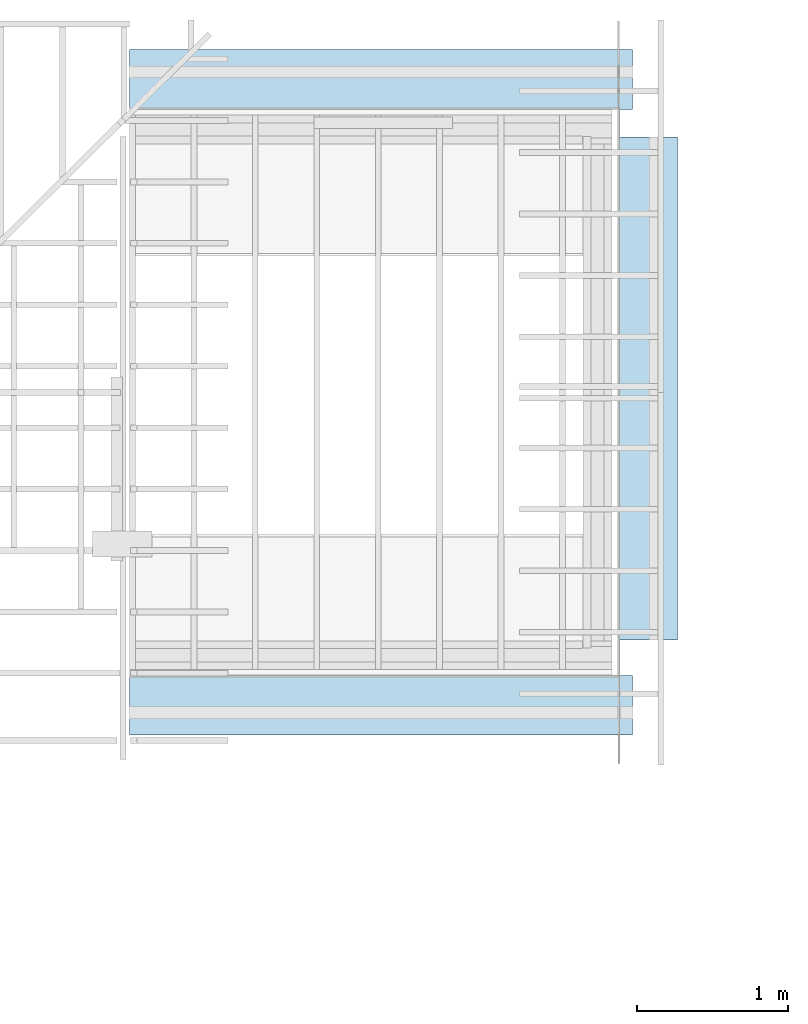
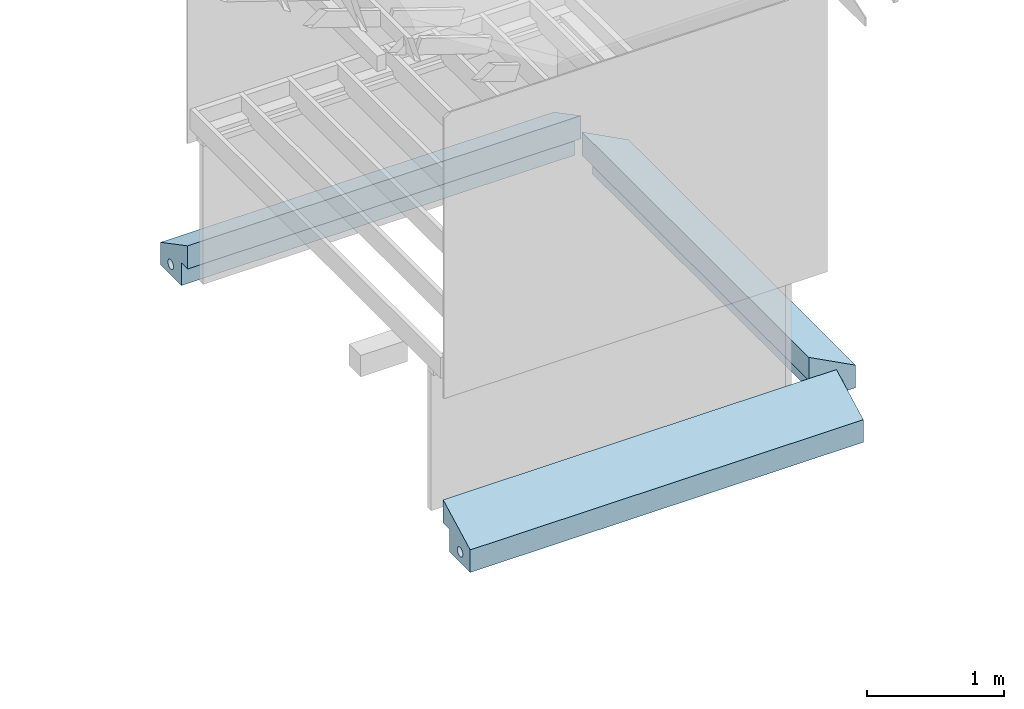
# Not in any storey, part 5 of 8: 3 footings.
"""IFC4 model written with IfcOpenShell, lengths in feet."""

from ifc_helpers import new_model, entity, si_unit, converted_unit, frame, origin_with_axes, origin_2d_with_axis, place, context, subcontext, project, polygons, material, element, save


model = new_model("IFC4")

# Units and contexts
model_context = context("Model", 3, precision=1e-05, world=origin_with_axes())
plan_context = context("Plan", 2, precision=1e-05, world=origin_2d_with_axis())
context_of_model_1 = context(None, 3, precision=1e-05, world=origin_with_axes())
context_of_model_2 = context(None, 3, precision=1e-05, world=origin_with_axes())
body_context = subcontext(model_context, "Body", "Model", "MODEL_VIEW")
ifc_project = project(units=[converted_unit("PLANEANGLEUNIT", "degree", entity("IfcReal", 0.0174532925199433), si_unit("PLANEANGLEUNIT", "RADIAN"), dimensions=[0, 0, 0, 0, 0, 0, 0]), converted_unit("AREAUNIT", "square foot", entity("IfcReal", 0.09290304), si_unit("AREAUNIT", "SQUARE_METRE"), dimensions=[2, 0, 0, 0, 0, 0, 0]), converted_unit("LENGTHUNIT", "foot", entity("IfcReal", 0.3048), si_unit("LENGTHUNIT", "METRE"), dimensions=[1, 0, 0, 0, 0, 0, 0]), converted_unit("VOLUMEUNIT", "cubic foot", entity("IfcReal", 0.0283168467116885), si_unit("VOLUMEUNIT", "CUBIC_METRE"), dimensions=[3, 0, 0, 0, 0, 0, 0])], contexts=[model_context, plan_context, context_of_model_1, context_of_model_2])

# Footings
ifc_material = material(Name="FILTER FABRIC OVER COARSE GRAVEL (NO)", Category="sand")
footing_1_placement = place(None, frame((-8.20750795950101, 9.42573459755404, -5.49999865021293), z_axis=(0.999999999999997, 0.0, 7.54979012640431e-08), x_axis=(7.54979012640431e-08, 0.0, -0.999999999999997)))
element("IfcFooting", 1, at=footing_1_placement, material=ifc_material, Name="Plane", ObjectType="Backfill", PredefinedType="USERDEFINED", context=body_context, shape_type="Tessellation", body=[
    polygons([(-0.336403906345367, 0.64263528585434, -2.71372056007385), (-0.361569315195084, 0.635001599788666, -2.71372056007385), (-0.384761482477188, 0.622605204582214, -2.71372056007385), (-0.405089259147644, 0.605922102928162, -2.71372056007385), (-0.421772688627243, 0.585593938827515, -2.71372056007385), (-0.434169232845306, 0.562402188777924, -2.71372056007385), (-1.34549736976624, -0.299155086278915, 8.19978809356689), (6.19066838680737e-07, 0.0, 8.19978809356689), (6.19066838680737e-07, 0.999586641788483, 8.19978809356689), (-0.666665971279144, 0.0, 8.19978809356689), (-0.662689328193665, 0.999585866928101, 8.19978809356689), (-0.666665971279144, -0.299155086278915, 8.19978809356689), (-0.310232996940613, 0.645212650299072, 8.19978809356689), (-0.284061670303345, 0.64263528585434, 8.19978809356689), (-0.258896738290787, 0.635001659393311, 8.19978809356689), (-0.235704496502876, 0.62260502576828, 8.19978809356689), (-0.215376317501068, 0.605922043323517, 8.19978809356689), (-0.198693662881851, 0.58559387922287, 8.19978809356689), (-0.18629752099514, 0.562402069568634, 8.19978809356689), (-0.17866313457489, 0.537236750125885, 8.19978809356689), (-0.176086127758026, 0.511066198348999, 8.19978809356689), (-0.17866313457489, 0.484895616769791, 8.19978809356689), (-0.18629752099514, 0.459731042385101, 8.19978809356689), (-0.198693662881851, 0.436537683010101, 8.19978809356689), (-0.215376317501068, 0.416211098432541, 8.19978809356689), (-0.235704496502876, 0.399528026580811, 8.19978809356689), (-0.258896708488464, 0.38713151216507, 8.19978809356689), (-0.284061670303345, 0.379497855901718, 8.19978809356689), (-0.310232996940613, 0.376918911933899, 8.19978809356689), (-0.336403071880341, 0.379497855901718, 8.19978809356689), (-0.361568480730057, 0.387131482362747, 8.19978809356689), (-0.384760707616806, 0.399528056383133, 8.19978809356689), (-0.405088424682617, 0.416211098432541, 8.19978809356689), (-0.421771883964539, 0.436537742614746, 8.19978809356689), (-0.43416839838028, 0.459731131792068, 8.19978809356689), (-0.441801637411118, 0.484895616769791, 8.19978809356689), (-0.444379419088364, 0.511066198348999, 8.19978809356689), (-0.441801637411118, 0.537236750125885, 8.19978809356689), (-0.43416839838028, 0.562402188777924, 8.19978809356689), (-0.421771854162216, 0.585593938827515, 8.19978809356689), (-0.405088424682617, 0.605922102928162, 8.19978809356689), (-0.384760648012161, 0.622605204582214, 8.19978809356689), (-0.361568480730057, 0.635001599788666, 8.19978809356689), (-0.336403071880341, 0.64263528585434, 8.19978809356689), (-0.441802471876144, 0.537236750125885, -2.71372056007385), (-0.444380253553391, 0.511066198348999, -2.71372056007385), (-0.441802471876144, 0.484895616769791, -2.71372056007385), (-0.434169232845306, 0.459731131792068, -2.71372056007385), (-0.421772718429565, 0.436537742614746, -2.71372056007385), (-0.405089229345322, 0.416211098432541, -2.71372056007385), (-0.38476151227951, 0.399528056383133, -2.71372056007385), (-0.361569315195084, 0.387131482362747, -2.71372056007385), (-0.336403906345367, 0.379497855901718, -2.71372056007385), (-0.31023383140564, 0.376918911933899, -2.71372056007385), (-0.284062504768372, 0.379497855901718, -2.71372056007385), (-0.258897542953491, 0.38713151216507, -2.71372056007385), (-0.235705330967903, 0.399528026580811, -2.71372056007385), (-0.215377151966095, 0.416211098432541, -2.71372056007385), (-0.198694482445717, 0.436537683010101, -2.71372056007385), (-0.186298340559006, 0.459731042385101, -2.71372056007385), (-0.178663939237595, 0.484895616769791, -2.71372056007385), (-0.176086947321892, 0.511066198348999, -2.71372056007385), (-0.178663939237595, 0.537236750125885, -2.71372056007385), (-0.186298340559006, 0.562402069568634, -2.71372056007385), (-0.198694482445717, 0.58559387922287, -2.71372056007385), (-0.215377151966095, 0.605922043323517, -2.71372056007385), (-0.235705330967903, 0.62260502576828, -2.71372056007385), (-0.258897572755814, 0.635001659393311, -2.71372056007385), (-0.284062504768372, 0.64263528585434, -2.71372056007385), (-0.31023383140564, 0.645212650299072, -2.71372056007385), (-0.666666805744171, -0.299155086278915, -2.71372056007385), (-0.662690162658691, 0.999585866928101, -2.71372056007385), (-0.666666805744171, 0.0, -2.71372056007385), (-2.04880194587531e-07, 0.999586641788483, -2.71372056007385), (-2.04880194587531e-07, 0.0, -2.71372056007385), (-1.34549808502197, -0.299155086278915, -2.71372056007385)], [[[47, 48, 49, 50, 51, 52, 53, 54, 55, 56, 57, 58, 59, 60, 61, 62, 74, 75, 73, 71, 76, 72, 46]], [[11, 37, 38, 39, 40, 41, 42, 43, 44, 13, 14, 15, 16, 17, 18, 19, 20, 21, 9]], [[37, 36, 47, 46]], [[24, 23, 60, 59]], [[36, 35, 48, 47]], [[38, 37, 46, 45]], [[23, 22, 61, 60]], [[72, 74, 62, 63, 64, 65, 66, 67, 68, 69, 70, 1, 2, 3, 4, 5, 6, 45, 46]], [[36, 37, 11, 7, 12, 10, 8, 9, 21, 22, 23, 24, 25, 26, 27, 28, 29, 30, 31, 32, 33, 34, 35]], [[25, 24, 59, 58]], [[39, 38, 45, 6]], [[26, 25, 58, 57]], [[40, 39, 6, 5]], [[27, 26, 57, 56]], [[14, 13, 70, 69]], [[41, 40, 5, 4]], [[28, 27, 56, 55]], [[15, 14, 69, 68]], [[42, 41, 4, 3]], [[7, 11, 72, 76]], [[29, 28, 55, 54]], [[16, 15, 68, 67]], [[43, 42, 3, 2]], [[9, 8, 75, 74]], [[30, 29, 54, 53]], [[17, 16, 67, 66]], [[44, 43, 2, 1]], [[11, 9, 74, 72]], [[31, 30, 53, 52]], [[18, 17, 66, 65]], [[13, 44, 1, 70]], [[10, 12, 71, 73]], [[32, 31, 52, 51]], [[19, 18, 65, 64]], [[12, 7, 76, 71]], [[33, 32, 51, 50]], [[20, 19, 64, 63]], [[8, 10, 73, 75]], [[34, 33, 50, 49]], [[21, 20, 63, 62]], [[35, 34, 49, 48]], [[22, 21, 62, 61]]], closed=True),
])
footing_2_placement = place(None, frame((-8.20750795950101, -3.45877931499731, -5.49999865021293), z_axis=(0.999999999999997, 0.0, 7.54979012640431e-08), x_axis=(7.54979012640431e-08, 0.0, -0.999999999999997)))
element("IfcFooting", 2, at=footing_2_placement, material=ifc_material, Name="Plane", ObjectType="Backfill", PredefinedType="USERDEFINED", context=body_context, shape_type="Tessellation", body=[
    polygons([(-0.336403906345367, -0.64263528585434, -2.71372056007385), (-0.361569315195084, -0.635001599788666, -2.71372056007385), (-0.384761482477188, -0.622605204582214, -2.71372056007385), (-0.405089259147644, -0.605922102928162, -2.71372056007385), (-0.421772688627243, -0.585593938827515, -2.71372056007385), (-0.434169232845306, -0.562402188777924, -2.71372056007385), (-1.34549736976624, 0.299155086278915, 8.19978809356689), (6.19066838680737e-07, 0.0, 8.19978809356689), (6.19066838680737e-07, -0.999586641788483, 8.19978809356689), (-0.666665971279144, 0.0, 8.19978809356689), (-0.662689328193665, -0.999585866928101, 8.19978809356689), (-0.666665971279144, 0.299155086278915, 8.19978809356689), (-0.310232996940613, -0.645212650299072, 8.19978809356689), (-0.284061670303345, -0.64263528585434, 8.19978809356689), (-0.258896738290787, -0.635001659393311, 8.19978809356689), (-0.235704496502876, -0.62260502576828, 8.19978809356689), (-0.215376317501068, -0.605922043323517, 8.19978809356689), (-0.198693662881851, -0.58559387922287, 8.19978809356689), (-0.18629752099514, -0.562402069568634, 8.19978809356689), (-0.17866313457489, -0.537236750125885, 8.19978809356689), (-0.176086127758026, -0.511066198348999, 8.19978809356689), (-0.17866313457489, -0.484895616769791, 8.19978809356689), (-0.18629752099514, -0.459731042385101, 8.19978809356689), (-0.198693662881851, -0.436537683010101, 8.19978809356689), (-0.215376317501068, -0.416211098432541, 8.19978809356689), (-0.235704496502876, -0.399528026580811, 8.19978809356689), (-0.258896708488464, -0.38713151216507, 8.19978809356689), (-0.284061670303345, -0.379497855901718, 8.19978809356689), (-0.310232996940613, -0.376918911933899, 8.19978809356689), (-0.336403071880341, -0.379497855901718, 8.19978809356689), (-0.361568480730057, -0.387131482362747, 8.19978809356689), (-0.384760707616806, -0.399528056383133, 8.19978809356689), (-0.405088424682617, -0.416211098432541, 8.19978809356689), (-0.421771883964539, -0.436537742614746, 8.19978809356689), (-0.43416839838028, -0.459731131792068, 8.19978809356689), (-0.441801637411118, -0.484895616769791, 8.19978809356689), (-0.444379419088364, -0.511066198348999, 8.19978809356689), (-0.441801637411118, -0.537236750125885, 8.19978809356689), (-0.43416839838028, -0.562402188777924, 8.19978809356689), (-0.421771854162216, -0.585593938827515, 8.19978809356689), (-0.405088424682617, -0.605922102928162, 8.19978809356689), (-0.384760648012161, -0.622605204582214, 8.19978809356689), (-0.361568480730057, -0.635001599788666, 8.19978809356689), (-0.336403071880341, -0.64263528585434, 8.19978809356689), (-0.441802471876144, -0.537236750125885, -2.71372056007385), (-0.444380253553391, -0.511066198348999, -2.71372056007385), (-0.441802471876144, -0.484895616769791, -2.71372056007385), (-0.434169232845306, -0.459731131792068, -2.71372056007385), (-0.421772718429565, -0.436537742614746, -2.71372056007385), (-0.405089229345322, -0.416211098432541, -2.71372056007385), (-0.38476151227951, -0.399528056383133, -2.71372056007385), (-0.361569315195084, -0.387131482362747, -2.71372056007385), (-0.336403906345367, -0.379497855901718, -2.71372056007385), (-0.31023383140564, -0.376918911933899, -2.71372056007385), (-0.284062504768372, -0.379497855901718, -2.71372056007385), (-0.258897542953491, -0.38713151216507, -2.71372056007385), (-0.235705330967903, -0.399528026580811, -2.71372056007385), (-0.215377151966095, -0.416211098432541, -2.71372056007385), (-0.198694482445717, -0.436537683010101, -2.71372056007385), (-0.186298340559006, -0.459731042385101, -2.71372056007385), (-0.178663939237595, -0.484895616769791, -2.71372056007385), (-0.176086947321892, -0.511066198348999, -2.71372056007385), (-0.178663939237595, -0.537236750125885, -2.71372056007385), (-0.186298340559006, -0.562402069568634, -2.71372056007385), (-0.198694482445717, -0.58559387922287, -2.71372056007385), (-0.215377151966095, -0.605922043323517, -2.71372056007385), (-0.235705330967903, -0.62260502576828, -2.71372056007385), (-0.258897572755814, -0.635001659393311, -2.71372056007385), (-0.284062504768372, -0.64263528585434, -2.71372056007385), (-0.31023383140564, -0.645212650299072, -2.71372056007385), (-0.666666805744171, 0.299155086278915, -2.71372056007385), (-0.662690162658691, -0.999585866928101, -2.71372056007385), (-0.666666805744171, 0.0, -2.71372056007385), (-2.04880194587531e-07, -0.999586641788483, -2.71372056007385), (-2.04880194587531e-07, 0.0, -2.71372056007385), (-1.34549808502197, 0.299155086278915, -2.71372056007385)], [[[47, 48, 49, 50, 51, 52, 53, 54, 55, 56, 57, 58, 59, 60, 61, 62, 74, 75, 73, 71, 76, 72, 46]], [[11, 37, 38, 39, 40, 41, 42, 43, 44, 13, 14, 15, 16, 17, 18, 19, 20, 21, 9]], [[37, 36, 47, 46]], [[24, 23, 60, 59]], [[36, 35, 48, 47]], [[38, 37, 46, 45]], [[23, 22, 61, 60]], [[72, 74, 62, 63, 64, 65, 66, 67, 68, 69, 70, 1, 2, 3, 4, 5, 6, 45, 46]], [[36, 37, 11, 7, 12, 10, 8, 9, 21, 22, 23, 24, 25, 26, 27, 28, 29, 30, 31, 32, 33, 34, 35]], [[25, 24, 59, 58]], [[39, 38, 45, 6]], [[26, 25, 58, 57]], [[40, 39, 6, 5]], [[27, 26, 57, 56]], [[14, 13, 70, 69]], [[41, 40, 5, 4]], [[28, 27, 56, 55]], [[15, 14, 69, 68]], [[42, 41, 4, 3]], [[7, 11, 72, 76]], [[29, 28, 55, 54]], [[16, 15, 68, 67]], [[43, 42, 3, 2]], [[9, 8, 75, 74]], [[30, 29, 54, 53]], [[17, 16, 67, 66]], [[44, 43, 2, 1]], [[11, 9, 74, 72]], [[31, 30, 53, 52]], [[18, 17, 66, 65]], [[13, 44, 1, 70]], [[10, 12, 71, 73]], [[32, 31, 52, 51]], [[19, 18, 65, 64]], [[12, 7, 76, 71]], [[33, 32, 51, 50]], [[20, 19, 64, 63]], [[8, 10, 73, 75]], [[34, 33, 50, 49]], [[21, 20, 63, 62]], [[35, 34, 49, 48]], [[22, 21, 62, 61]]], closed=True),
])
footing_3_placement = place(None, frame((-0.0283198572910364, 0.326337581231525, -5.49999865021293), z_axis=(-4.37113882867379e-08, 0.999999999999999, -3.30011807777566e-15), x_axis=(7.54979012640431e-08, 0.0, -0.999999999999997)))
element("IfcFooting", 3, at=footing_3_placement, material=ifc_material, Name="Plane", ObjectType="Backfill", PredefinedType="USERDEFINED", context=body_context, shape_type="Tessellation", body=[
    polygons([(-0.336403906345367, -0.64263528585434, -2.71372056007385), (-0.361569315195084, -0.635001599788666, -2.71372056007385), (-0.384761482477188, -0.622605204582214, -2.71372056007385), (-0.405089259147644, -0.605922102928162, -2.71372056007385), (-0.421772688627243, -0.585593938827515, -2.71372056007385), (-0.434169232845306, -0.562402188777924, -2.71372056007385), (-1.34549736976624, 0.299155086278915, 8.19978809356689), (6.19066838680737e-07, 0.0, 8.19978809356689), (6.19066838680737e-07, -0.999586641788483, 8.19978809356689), (-0.666665971279144, 0.0, 8.19978809356689), (-0.662689328193665, -0.999585866928101, 8.19978809356689), (-0.666665971279144, 0.299155086278915, 8.19978809356689), (-0.310232996940613, -0.645212650299072, 8.19978809356689), (-0.284061670303345, -0.64263528585434, 8.19978809356689), (-0.258896738290787, -0.635001659393311, 8.19978809356689), (-0.235704496502876, -0.62260502576828, 8.19978809356689), (-0.215376317501068, -0.605922043323517, 8.19978809356689), (-0.198693662881851, -0.58559387922287, 8.19978809356689), (-0.18629752099514, -0.562402069568634, 8.19978809356689), (-0.17866313457489, -0.537236750125885, 8.19978809356689), (-0.176086127758026, -0.511066198348999, 8.19978809356689), (-0.17866313457489, -0.484895616769791, 8.19978809356689), (-0.18629752099514, -0.459731042385101, 8.19978809356689), (-0.198693662881851, -0.436537683010101, 8.19978809356689), (-0.215376317501068, -0.416211098432541, 8.19978809356689), (-0.235704496502876, -0.399528026580811, 8.19978809356689), (-0.258896708488464, -0.38713151216507, 8.19978809356689), (-0.284061670303345, -0.379497855901718, 8.19978809356689), (-0.310232996940613, -0.376918911933899, 8.19978809356689), (-0.336403071880341, -0.379497855901718, 8.19978809356689), (-0.361568480730057, -0.387131482362747, 8.19978809356689), (-0.384760707616806, -0.399528056383133, 8.19978809356689), (-0.405088424682617, -0.416211098432541, 8.19978809356689), (-0.421771883964539, -0.436537742614746, 8.19978809356689), (-0.43416839838028, -0.459731131792068, 8.19978809356689), (-0.441801637411118, -0.484895616769791, 8.19978809356689), (-0.444379419088364, -0.511066198348999, 8.19978809356689), (-0.441801637411118, -0.537236750125885, 8.19978809356689), (-0.43416839838028, -0.562402188777924, 8.19978809356689), (-0.421771854162216, -0.585593938827515, 8.19978809356689), (-0.405088424682617, -0.605922102928162, 8.19978809356689), (-0.384760648012161, -0.622605204582214, 8.19978809356689), (-0.361568480730057, -0.635001599788666, 8.19978809356689), (-0.336403071880341, -0.64263528585434, 8.19978809356689), (-0.441802471876144, -0.537236750125885, -2.71372056007385), (-0.444380253553391, -0.511066198348999, -2.71372056007385), (-0.441802471876144, -0.484895616769791, -2.71372056007385), (-0.434169232845306, -0.459731131792068, -2.71372056007385), (-0.421772718429565, -0.436537742614746, -2.71372056007385), (-0.405089229345322, -0.416211098432541, -2.71372056007385), (-0.38476151227951, -0.399528056383133, -2.71372056007385), (-0.361569315195084, -0.387131482362747, -2.71372056007385), (-0.336403906345367, -0.379497855901718, -2.71372056007385), (-0.31023383140564, -0.376918911933899, -2.71372056007385), (-0.284062504768372, -0.379497855901718, -2.71372056007385), (-0.258897542953491, -0.38713151216507, -2.71372056007385), (-0.235705330967903, -0.399528026580811, -2.71372056007385), (-0.215377151966095, -0.416211098432541, -2.71372056007385), (-0.198694482445717, -0.436537683010101, -2.71372056007385), (-0.186298340559006, -0.459731042385101, -2.71372056007385), (-0.178663939237595, -0.484895616769791, -2.71372056007385), (-0.176086947321892, -0.511066198348999, -2.71372056007385), (-0.178663939237595, -0.537236750125885, -2.71372056007385), (-0.186298340559006, -0.562402069568634, -2.71372056007385), (-0.198694482445717, -0.58559387922287, -2.71372056007385), (-0.215377151966095, -0.605922043323517, -2.71372056007385), (-0.235705330967903, -0.62260502576828, -2.71372056007385), (-0.258897572755814, -0.635001659393311, -2.71372056007385), (-0.284062504768372, -0.64263528585434, -2.71372056007385), (-0.31023383140564, -0.645212650299072, -2.71372056007385), (-0.666666805744171, 0.299155086278915, -2.71372056007385), (-0.662690162658691, -0.999585866928101, -2.71372056007385), (-0.666666805744171, 0.0, -2.71372056007385), (-2.04880194587531e-07, -0.999586641788483, -2.71372056007385), (-2.04880194587531e-07, 0.0, -2.71372056007385), (-1.34549808502197, 0.299155086278915, -2.71372056007385)], [[[47, 48, 49, 50, 51, 52, 53, 54, 55, 56, 57, 58, 59, 60, 61, 62, 74, 75, 73, 71, 76, 72, 46]], [[11, 37, 38, 39, 40, 41, 42, 43, 44, 13, 14, 15, 16, 17, 18, 19, 20, 21, 9]], [[37, 36, 47, 46]], [[24, 23, 60, 59]], [[36, 35, 48, 47]], [[38, 37, 46, 45]], [[23, 22, 61, 60]], [[72, 74, 62, 63, 64, 65, 66, 67, 68, 69, 70, 1, 2, 3, 4, 5, 6, 45, 46]], [[36, 37, 11, 7, 12, 10, 8, 9, 21, 22, 23, 24, 25, 26, 27, 28, 29, 30, 31, 32, 33, 34, 35]], [[25, 24, 59, 58]], [[39, 38, 45, 6]], [[26, 25, 58, 57]], [[40, 39, 6, 5]], [[27, 26, 57, 56]], [[14, 13, 70, 69]], [[41, 40, 5, 4]], [[28, 27, 56, 55]], [[15, 14, 69, 68]], [[42, 41, 4, 3]], [[7, 11, 72, 76]], [[29, 28, 55, 54]], [[16, 15, 68, 67]], [[43, 42, 3, 2]], [[9, 8, 75, 74]], [[30, 29, 54, 53]], [[17, 16, 67, 66]], [[44, 43, 2, 1]], [[11, 9, 74, 72]], [[31, 30, 53, 52]], [[18, 17, 66, 65]], [[13, 44, 1, 70]], [[10, 12, 71, 73]], [[32, 31, 52, 51]], [[19, 18, 65, 64]], [[12, 7, 76, 71]], [[33, 32, 51, 50]], [[20, 19, 64, 63]], [[8, 10, 73, 75]], [[34, 33, 50, 49]], [[21, 20, 63, 62]], [[35, 34, 49, 48]], [[22, 21, 62, 61]]], closed=True),
])

save(model, "model.ifc")
